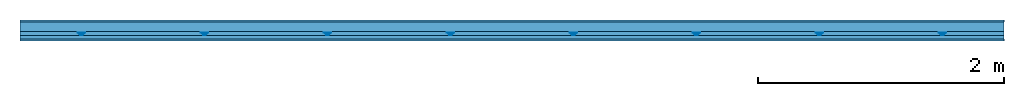
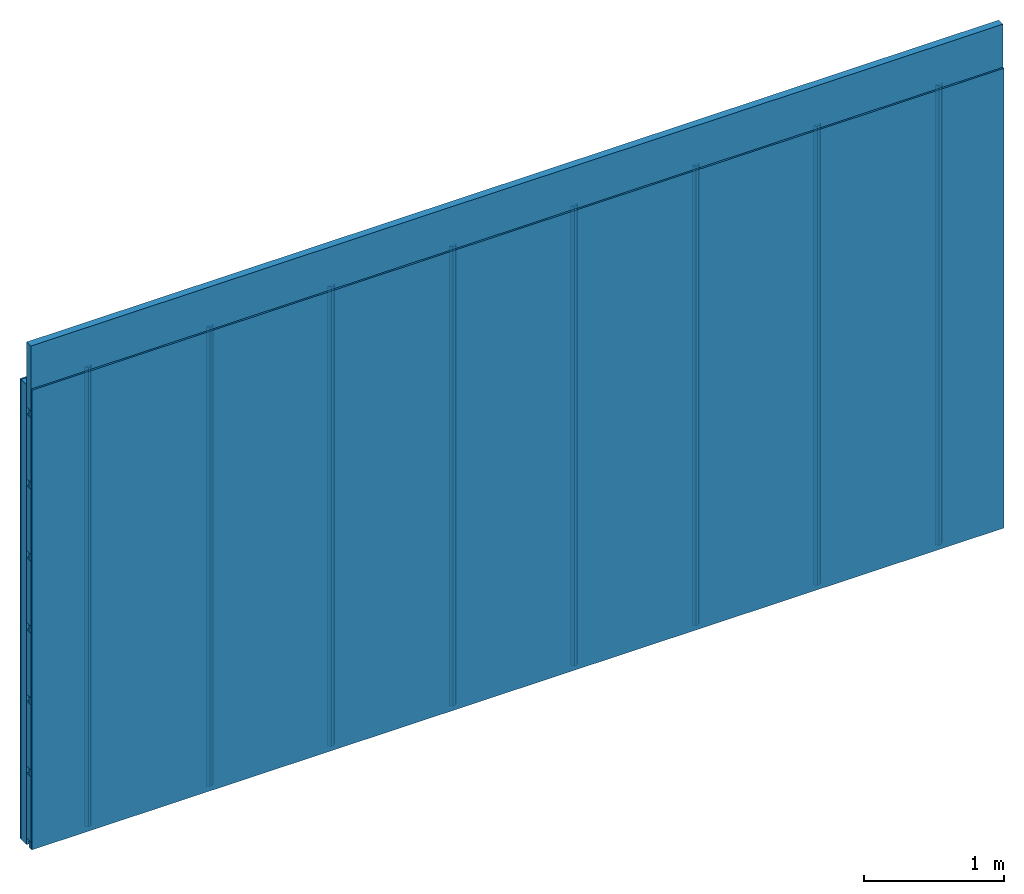
# One storey: 4 members, 2 plates, 1 element without a shape of its own.
"""IFC4 building model written with IfcOpenShell, lengths in metres."""

from ifc_helpers import new_model, si_unit, derived_unit, direction, frame, frame_2d, origin, origin_with_axes, place, context, project, spatial, polyline, rectangle, outline, extrude, material, layer, layer_set, type_object, element, aggregate, save


model = new_model("IFC4")

# Units and contexts
plan_context = context("Plan", 3, precision=1e-05, world=origin(), true_north=direction((0.0, 1.0)))
model_context = context("Model", 3, precision=1e-05, world=origin(), true_north=direction((0.0, 1.0)))
ifc_project = project(units=[si_unit("LENGTHUNIT", "METRE"), derived_unit("SOUNDPRESSUREUNIT", [(si_unit("PRESSUREUNIT", "PASCAL", prefix="MICRO"), 0)]), si_unit("ENERGYUNIT", "JOULE", prefix="MEGA"), si_unit("MASSUNIT", "GRAM", prefix="KILO"), derived_unit("THERMALTRANSMITTANCEUNIT", [(si_unit("POWERUNIT", "WATT"), 1), (si_unit("AREAUNIT", "SQUARE_METRE"), -1), (si_unit("THERMODYNAMICTEMPERATUREUNIT", "KELVIN"), -1)]), derived_unit("AREADENSITYUNIT", [(si_unit("MASSUNIT", "GRAM", prefix="KILO"), 1), (si_unit("AREAUNIT", "SQUARE_METRE"), -1)]), derived_unit("USERDEFINED", [(si_unit("ENERGYUNIT", "JOULE", prefix="MEGA"), 1), (si_unit("AREAUNIT", "SQUARE_METRE"), -1)])], contexts=[plan_context, model_context])

# Site, building, storey
site = spatial("IfcSite", under=ifc_project)
building_placement = place(None, origin())
building = spatial("IfcBuilding", under=site, at=building_placement)
storey_placement = place(building_placement, origin())
storey = spatial("IfcBuildingStorey", under=building, at=storey_placement)

# Wall, members, plates
ifc_material_1 = material(Name="Glued joints")
ifc_layer_1 = layer(ifc_material_1, 0.0, Name="Surface")
ifc_material_2 = material(Category="03.007")
ifc_layer_2 = layer(ifc_material_2, 0.015, Name="1st layer")
ifc_material_3 = material(Name="of the art")
ifc_layer_3 = layer(ifc_material_3, 0.0, Name="Bond")
ifc_layer_4 = layer(None, 0.08, Name="Support")
ifc_material_4 = material(Name="no composite action")
ifc_layer_5 = layer(ifc_material_4, 0.0, Name="Bond")
ifc_layer_6 = layer(None, 0.03, Name="Coupling")
ifc_layer_7 = layer(None, 0.03, Name="Battens / profiles")
ifc_material_5 = material(Name="Plasterboard type A", Category="03.008")
ifc_layer_8 = layer(ifc_material_5, 0.015, Name="Covering 1st layer")
ifc_layer_9 = layer(ifc_material_1, 0.0, Name="Surface")
ifc_layer_set = layer_set([ifc_layer_1, ifc_layer_2, ifc_layer_3, ifc_layer_4, ifc_layer_5, ifc_layer_6, ifc_layer_7, ifc_layer_8, ifc_layer_9])
wall_type = type_object("IfcWallType", Name="C0112", PredefinedType="NOTDEFINED", material=ifc_layer_set)
wall_placement = place(None, frame((0.0, 0.0, 0.0), z_axis=(0.0, -1.0, 0.0), x_axis=(1.0, 0.0, 0.0)))
wall = element("IfcWall", 1, at=wall_placement, inside=storey, type_object=wall_type, material=ifc_layer_set, Name="Wall #1")
ifc_material_6 = material()
member_1_placement = place(wall_placement, origin())
member_1 = element("IfcMember", 2, at=member_1_placement, material=ifc_material_6, Name="Support", context=plan_context, shape_type="SweptSolid", body=[
    extrude(rectangle(XDim=1.0, YDim=0.08, at=frame_2d((0.5, 0.04), x_axis=(1.0, 0.0))), frame((0.0, 4.0, 0.015), z_axis=(0.0, -1.0, 0.0), x_axis=(1.0, 0.0, 0.0)), (0.0, 0.0, 1.0), 4.0),
    extrude(rectangle(XDim=1.0, YDim=0.08, at=frame_2d((0.5, 0.04), x_axis=(1.0, 0.0))), frame((1.0, 4.0, 0.015), z_axis=(0.0, -1.0, 0.0), x_axis=(1.0, 0.0, 0.0)), (0.0, 0.0, 1.0), 4.0),
    extrude(rectangle(XDim=1.0, YDim=0.08, at=frame_2d((0.5, 0.04), x_axis=(1.0, 0.0))), frame((2.0, 4.0, 0.015), z_axis=(0.0, -1.0, 0.0), x_axis=(1.0, 0.0, 0.0)), (0.0, 0.0, 1.0), 4.0),
    extrude(rectangle(XDim=1.0, YDim=0.08, at=frame_2d((0.5, 0.04), x_axis=(1.0, 0.0))), frame((3.0, 4.0, 0.015), z_axis=(0.0, -1.0, 0.0), x_axis=(1.0, 0.0, 0.0)), (0.0, 0.0, 1.0), 4.0),
    extrude(rectangle(XDim=1.0, YDim=0.08, at=frame_2d((0.5, 0.04), x_axis=(1.0, 0.0))), frame((4.0, 4.0, 0.015), z_axis=(0.0, -1.0, 0.0), x_axis=(1.0, 0.0, 0.0)), (0.0, 0.0, 1.0), 4.0),
    extrude(rectangle(XDim=1.0, YDim=0.08, at=frame_2d((0.5, 0.04), x_axis=(1.0, 0.0))), frame((5.0, 4.0, 0.015), z_axis=(0.0, -1.0, 0.0), x_axis=(1.0, 0.0, 0.0)), (0.0, 0.0, 1.0), 4.0),
    extrude(rectangle(XDim=1.0, YDim=0.08, at=frame_2d((0.5, 0.04), x_axis=(1.0, 0.0))), frame((6.0, 4.0, 0.015), z_axis=(0.0, -1.0, 0.0), x_axis=(1.0, 0.0, 0.0)), (0.0, 0.0, 1.0), 4.0),
    extrude(rectangle(XDim=1.0, YDim=0.08, at=frame_2d((0.5, 0.04), x_axis=(1.0, 0.0))), frame((7.0, 4.0, 0.015), z_axis=(0.0, -1.0, 0.0), x_axis=(1.0, 0.0, 0.0)), (0.0, 0.0, 1.0), 4.0),
])
ifc_material_7 = material()
member_2_placement = place(wall_placement, origin())
member_2 = element("IfcMember", 3, at=member_2_placement, material=ifc_material_7, Name="Coupling", context=plan_context, shape_type="SweptSolid", body=[
    extrude(outline(polyline([(0.0, 0.0), (0.06, 0.0), (0.04, 0.02), (0.02, 0.02), (0.0, 0.0)])), frame((0.47, 4.0, 0.105), z_axis=(0.0, -1.0, 0.0), x_axis=(1.0, 0.0, 0.0)), (0.0, 0.0, 1.0), 4.0),
    extrude(outline(polyline([(0.0, 0.0), (0.06, 0.0), (0.04, 0.02), (0.02, 0.02), (0.0, 0.0)])), frame((1.47, 4.0, 0.105), z_axis=(0.0, -1.0, 0.0), x_axis=(1.0, 0.0, 0.0)), (0.0, 0.0, 1.0), 4.0),
    extrude(outline(polyline([(0.0, 0.0), (0.06, 0.0), (0.04, 0.02), (0.02, 0.02), (0.0, 0.0)])), frame((2.47, 4.0, 0.105), z_axis=(0.0, -1.0, 0.0), x_axis=(1.0, 0.0, 0.0)), (0.0, 0.0, 1.0), 4.0),
    extrude(outline(polyline([(0.0, 0.0), (0.06, 0.0), (0.04, 0.02), (0.02, 0.02), (0.0, 0.0)])), frame((3.47, 4.0, 0.105), z_axis=(0.0, -1.0, 0.0), x_axis=(1.0, 0.0, 0.0)), (0.0, 0.0, 1.0), 4.0),
    extrude(outline(polyline([(0.0, 0.0), (0.06, 0.0), (0.04, 0.02), (0.02, 0.02), (0.0, 0.0)])), frame((4.47, 4.0, 0.105), z_axis=(0.0, -1.0, 0.0), x_axis=(1.0, 0.0, 0.0)), (0.0, 0.0, 1.0), 4.0),
    extrude(outline(polyline([(0.0, 0.0), (0.06, 0.0), (0.04, 0.02), (0.02, 0.02), (0.0, 0.0)])), frame((5.47, 4.0, 0.105), z_axis=(0.0, -1.0, 0.0), x_axis=(1.0, 0.0, 0.0)), (0.0, 0.0, 1.0), 4.0),
    extrude(outline(polyline([(0.0, 0.0), (0.06, 0.0), (0.04, 0.02), (0.02, 0.02), (0.0, 0.0)])), frame((6.47, 4.0, 0.105), z_axis=(0.0, -1.0, 0.0), x_axis=(1.0, 0.0, 0.0)), (0.0, 0.0, 1.0), 4.0),
    extrude(outline(polyline([(0.0, 0.0), (0.06, 0.0), (0.04, 0.02), (0.02, 0.02), (0.0, 0.0)])), frame((7.47, 4.0, 0.105), z_axis=(0.0, -1.0, 0.0), x_axis=(1.0, 0.0, 0.0)), (0.0, 0.0, 1.0), 4.0),
])
member_3_placement = place(wall_placement, origin())
member_3 = element("IfcMember", 4, at=member_3_placement, material=ifc_material_7, Name="Battens / profiles", context=plan_context, shape_type="SweptSolid", body=[
    extrude(rectangle(XDim=0.06, YDim=0.03, at=frame_2d((0.03, 0.015), x_axis=(1.0, 0.0))), frame((0.0, 0.0, 0.125), z_axis=(1.0, 0.0, 0.0), x_axis=(0.0, 1.0, 0.0)), (0.0, 0.0, 1.0), 8.0),
    extrude(rectangle(XDim=0.06, YDim=0.03, at=frame_2d((0.03, 0.015), x_axis=(1.0, 0.0))), frame((0.0, 0.625, 0.125), z_axis=(1.0, 0.0, 0.0), x_axis=(0.0, 1.0, 0.0)), (0.0, 0.0, 1.0), 8.0),
    extrude(rectangle(XDim=0.06, YDim=0.03, at=frame_2d((0.03, 0.015), x_axis=(1.0, 0.0))), frame((0.0, 1.25, 0.125), z_axis=(1.0, 0.0, 0.0), x_axis=(0.0, 1.0, 0.0)), (0.0, 0.0, 1.0), 8.0),
    extrude(rectangle(XDim=0.06, YDim=0.03, at=frame_2d((0.03, 0.015), x_axis=(1.0, 0.0))), frame((0.0, 1.875, 0.125), z_axis=(1.0, 0.0, 0.0), x_axis=(0.0, 1.0, 0.0)), (0.0, 0.0, 1.0), 8.0),
    extrude(rectangle(XDim=0.06, YDim=0.03, at=frame_2d((0.03, 0.015), x_axis=(1.0, 0.0))), frame((0.0, 2.5, 0.125), z_axis=(1.0, 0.0, 0.0), x_axis=(0.0, 1.0, 0.0)), (0.0, 0.0, 1.0), 8.0),
    extrude(rectangle(XDim=0.06, YDim=0.03, at=frame_2d((0.03, 0.015), x_axis=(1.0, 0.0))), frame((0.0, 3.125, 0.125), z_axis=(1.0, 0.0, 0.0), x_axis=(0.0, 1.0, 0.0)), (0.0, 0.0, 1.0), 8.0),
    extrude(rectangle(XDim=0.06, YDim=0.03, at=frame_2d((0.03, 0.015), x_axis=(1.0, 0.0))), frame((0.0, 3.75, 0.125), z_axis=(1.0, 0.0, 0.0), x_axis=(0.0, 1.0, 0.0)), (0.0, 0.0, 1.0), 8.0),
])
ifc_material_8 = material()
member_4_placement = place(wall_placement, origin())
member_4 = element("IfcMember", 5, at=member_4_placement, material=ifc_material_8, Name="Cavity", context=plan_context, shape_type="SweptSolid", body=[
    extrude(rectangle(XDim=0.565, YDim=0.06, at=frame_2d((0.2825, 0.03), x_axis=(1.0, 0.0))), frame((0.0, 0.06, 0.095), z_axis=(1.0, 0.0, 0.0), x_axis=(0.0, 1.0, 0.0)), (0.0, 0.0, 1.0), 8.0),
    extrude(rectangle(XDim=0.565, YDim=0.06, at=frame_2d((0.2825, 0.03), x_axis=(1.0, 0.0))), frame((0.0, 0.685, 0.095), z_axis=(1.0, 0.0, 0.0), x_axis=(0.0, 1.0, 0.0)), (0.0, 0.0, 1.0), 8.0),
    extrude(rectangle(XDim=0.565, YDim=0.06, at=frame_2d((0.2825, 0.03), x_axis=(1.0, 0.0))), frame((0.0, 1.31, 0.095), z_axis=(1.0, 0.0, 0.0), x_axis=(0.0, 1.0, 0.0)), (0.0, 0.0, 1.0), 8.0),
    extrude(rectangle(XDim=0.565, YDim=0.06, at=frame_2d((0.2825, 0.03), x_axis=(1.0, 0.0))), frame((0.0, 1.935, 0.095), z_axis=(1.0, 0.0, 0.0), x_axis=(0.0, 1.0, 0.0)), (0.0, 0.0, 1.0), 8.0),
    extrude(rectangle(XDim=0.565, YDim=0.06, at=frame_2d((0.2825, 0.03), x_axis=(1.0, 0.0))), frame((0.0, 2.56, 0.095), z_axis=(1.0, 0.0, 0.0), x_axis=(0.0, 1.0, 0.0)), (0.0, 0.0, 1.0), 8.0),
    extrude(rectangle(XDim=0.565, YDim=0.06, at=frame_2d((0.2825, 0.03), x_axis=(1.0, 0.0))), frame((0.0, 3.185, 0.095), z_axis=(1.0, 0.0, 0.0), x_axis=(0.0, 1.0, 0.0)), (0.0, 0.0, 1.0), 8.0),
    extrude(rectangle(XDim=0.565, YDim=0.06, at=frame_2d((0.2825, 0.03), x_axis=(1.0, 0.0))), frame((0.0, 3.81, 0.095), z_axis=(1.0, 0.0, 0.0), x_axis=(0.0, 1.0, 0.0)), (0.0, 0.0, 1.0), 8.0),
])
plate_1_placement = place(wall_placement, origin())
plate_1 = element("IfcPlate", 6, at=plate_1_placement, material=ifc_material_2, Name="1st layer", context=plan_context, shape_type="SweptSolid", body=[
    extrude(rectangle(XDim=8.0, YDim=4.0, at=frame_2d((4.0, 2.0), x_axis=(1.0, 0.0))), origin_with_axes(), (0.0, 0.0, 1.0), 0.015),
])
plate_2_placement = place(wall_placement, origin())
plate_2 = element("IfcPlate", 7, at=plate_2_placement, material=ifc_material_5, Name="Covering 1st layer", context=plan_context, shape_type="SweptSolid", body=[
    extrude(rectangle(XDim=8.0, YDim=4.0, at=frame_2d((4.0, 2.0), x_axis=(1.0, 0.0))), frame((0.0, 0.0, 0.155), z_axis=(0.0, 0.0, 1.0), x_axis=(1.0, 0.0, 0.0)), (0.0, 0.0, 1.0), 0.015),
])
aggregate(wall, [plate_1, member_1, member_2, member_3, member_4, plate_2])

save(model, "model.ifc")
